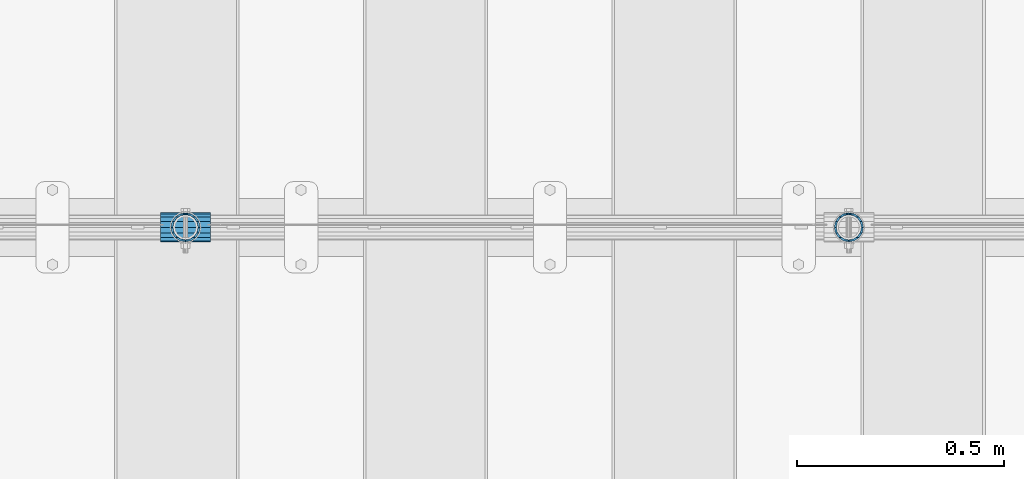
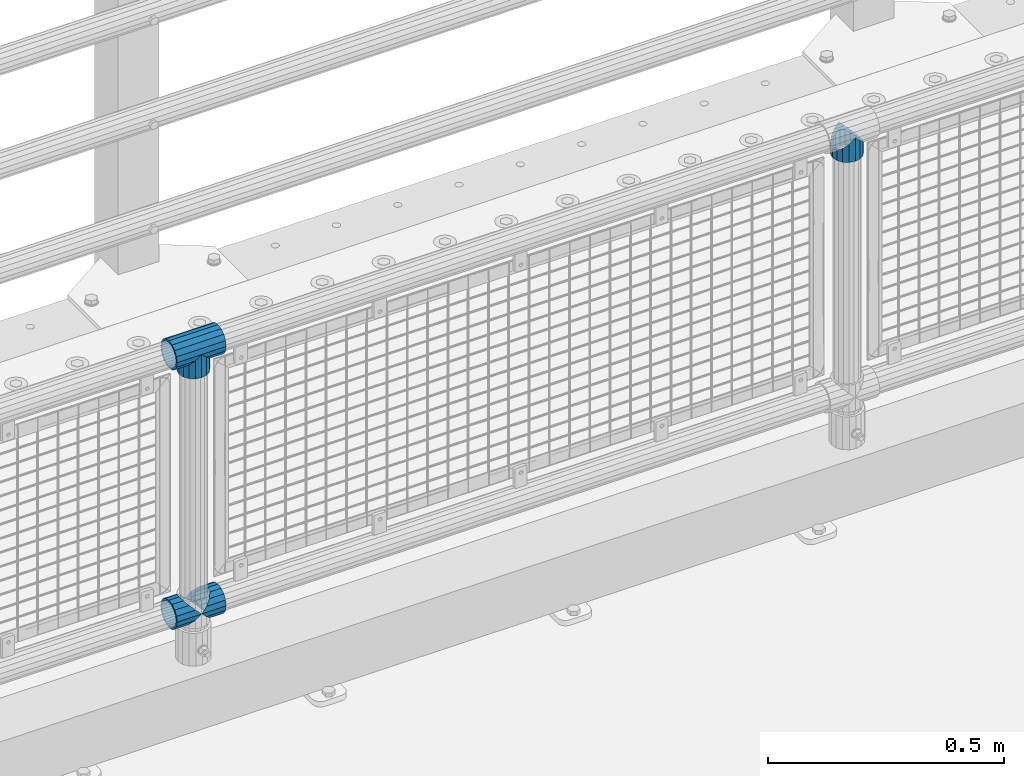
# One storey, part 154 of 257: 5 beams.
"""IFC2X3 building model written with IfcOpenShell, lengths in millimetres."""

from ifc_helpers import new_model, si_unit, frame, origin_with_axes, place, context, subcontext, project, spatial, faceted_brep, material, type_object, element, save


model = new_model("IFC2X3")

# Units and contexts
model_context = context("Model", 3, precision=1e-05, world=origin_with_axes())
body_context = subcontext(model_context, "Body", "Model", "MODEL_VIEW")
ifc_project = project(units=[si_unit("LENGTHUNIT", "METRE", prefix="MILLI"), si_unit("AREAUNIT", "SQUARE_METRE"), si_unit("VOLUMEUNIT", "CUBIC_METRE"), si_unit("MASSUNIT", "GRAM", prefix="KILO"), si_unit("TIMEUNIT", "SECOND"), si_unit("PLANEANGLEUNIT", "RADIAN"), si_unit("SOLIDANGLEUNIT", "STERADIAN"), si_unit("THERMODYNAMICTEMPERATUREUNIT", "DEGREE_CELSIUS"), si_unit("LUMINOUSINTENSITYUNIT", "LUMEN")], contexts=[model_context])

# Site, building, storey
site_placement = place(None, origin_with_axes())
site = spatial("IfcSite", under=ifc_project, at=site_placement, CompositionType="ELEMENT")
building_placement = place(site_placement, origin_with_axes())
building = spatial("IfcBuilding", under=site, at=building_placement, Name="Standard", CompositionType="ELEMENT")
storey_placement = place(building_placement, origin_with_axes())
storey = spatial("IfcBuildingStorey", under=building, at=storey_placement, Name="Undefined", CompositionType="ELEMENT", Elevation=0.0)

# Beams
ifc_material = material(Name="Misc_Undefined")
beam_type = type_object("IfcBeamType", PredefinedType="NOTDEFINED")
beam_1_placement = place(storey_placement, frame((51071.0, 10664.5, 969.849999999999), z_axis=(0.0, 1.0, 0.0), x_axis=(0.0, 0.0, -1.0)))
element("IfcBeam", 1, at=beam_1_placement, inside=storey, type_object=beam_type, material=ifc_material, context=body_context, shape_type="Brep", body=[
    faceted_brep([(0.0, 0.0, 35.1499999999996), (13.4513226476338, 13.4513226476329, 32.4743655677721), (13.4513226476338, -13.4513226476329, 32.4743655677721), (32.4743655677739, -32.4743655677717, -13.4513226476338), (32.4743655677739, -26.8123795176755, -13.4513226476338), (27.1226768591005, -21.4606908090117, -21.4606908090118), (24.8548033587067, -16.3810424080045, -24.8548033587067), (24.8548033587067, -24.8548033587072, -24.8548033587067), (13.4513226476338, -13.4513226476329, -32.4743655677721), (13.4513226476338, 13.4513226476329, -32.4743655677721), (0.0, 0.0, -35.1499999999996), (20.0882031229849, -11.6144421722805, -28.0397438117179), (16.6306603983685, 0.0, -30.3500000000004), (20.0882031229849, 11.6144421722805, -28.0397438117179), (24.8548033587067, 16.3810424080013, -24.8548033587067), (24.8548033587067, 24.8548033587072, -24.8548033587067), (32.4743655677739, 26.8123795176754, -13.4513226476338), (32.4743655677739, 32.4743655677717, -13.4513226476338), (27.1226768591005, 21.4606908090117, -21.4606908090118), (35.1500000000015, 30.35, 0.0), (35.1500000000015, 35.15, 0.0), (32.8397438117172, 28.0397438117175, -11.6144421722802), (32.8397438117172, 28.0397438117175, 11.6144421722802), (32.4743655677739, 26.8123795176755, 13.4513226476338), (32.4743655677739, 32.4743655677717, 13.4513226476338), (27.122676859115, 21.4606908090117, 21.4606908090118), (24.8548033587067, 16.3810424080013, 24.8548033587067), (24.8548033587067, 24.8548033587072, 24.8548033587067), (20.0882031229849, 11.6144421722805, 28.0397438117179), (16.6306603983758, 0.0, 30.3500000000004), (20.0882031229849, -11.6144421722805, 28.0397438117179), (24.8548033587067, -16.3810424080013, 24.8548033587067), (24.8548033587067, -24.8548033587072, 24.8548033587067), (27.122676859115, -21.4606908090117, 21.4606908090118), (32.4743655677739, -26.8123795176754, 13.4513226476338), (32.4743655677739, -32.4743655677717, 13.4513226476338), (32.8397438117172, -28.0397438117175, 11.6144421722802), (35.1500000000015, -30.35, 0.0), (35.1500000000015, -35.1499999999996, 0.0), (32.8397438117172, -28.0397438117175, -11.6144421722802), (60.1500000000015, -24.8548033587072, -24.8548033587067), (60.1500000000015, -32.4743655677717, -13.4513226476338), (60.1500000000015, -13.4513226476329, -32.4743655677721), (60.1500000000015, 0.0, -35.1499999999996), (60.1500000000015, 13.4513226476329, -32.4743655677721), (60.1500000000015, 24.8548033587072, -24.8548033587067), (60.1500000000015, 32.4743655677717, -13.4513226476338), (60.1500000000015, 35.15, 0.0), (60.1500000000015, 32.4743655677717, 13.4513226476338), (60.1500000000015, 24.8548033587072, 24.8548033587067), (60.1500000000015, 13.4513226476329, 32.4743655677721), (60.1500000000015, 0.0, 35.1499999999996), (60.1500000000015, -13.4513226476329, 32.4743655677721), (60.1500000000015, -24.8548033587072, 24.8548033587067), (60.1500000000015, -32.4743655677717, 13.4513226476338), (60.1500000000015, -35.15, 0.0), (60.1500000000015, -21.4606908090117, 21.4606908090118), (60.1500000000015, -11.6144421722805, 28.0397438117179), (60.1500000000015, 0.0, 30.3500000000004), (60.1500000000015, 11.6144421722805, 28.0397438117179), (60.1500000000015, 21.4606908090117, 21.4606908090118), (60.1500000000015, 28.0397438117175, 11.6144421722802), (60.1500000000015, 30.35, 0.0), (60.1500000000015, 28.0397438117175, -11.6144421722802), (60.1500000000015, 21.4606908090117, -21.4606908090118), (60.1500000000015, 11.6144421722805, -28.0397438117179), (60.1500000000015, 0.0, -30.3500000000004), (60.1500000000015, -11.6144421722805, -28.0397438117179), (60.1500000000015, -21.4606908090117, -21.4606908090118), (60.1500000000015, -28.0397438117175, -11.6144421722802), (60.1500000000015, -30.35, 0.0), (60.1500000000015, -28.0397438117175, 11.6144421722802)], [[[0, 1, 2]], [[3, 4, 5, 6, 7]], [[8, 9, 10]], [[7, 6, 11, 12, 13, 14, 15, 9, 8]], [[16, 17, 15, 14, 18]], [[19, 20, 17, 16, 21]], [[22, 23, 24, 20, 19]], [[25, 26, 27, 24, 23]], [[2, 1, 27, 26, 28, 29, 30, 31, 32]], [[32, 31, 33, 34, 35]], [[35, 34, 36, 37, 38]], [[38, 37, 39, 4, 3]], [[40, 41, 3, 7]], [[42, 40, 7, 8]], [[43, 42, 8, 10]], [[44, 43, 10, 9]], [[45, 44, 9, 15]], [[46, 45, 15, 17]], [[47, 46, 17, 20]], [[48, 47, 20, 24]], [[49, 48, 24, 27]], [[50, 49, 27, 1]], [[51, 50, 1, 0]], [[52, 51, 0, 2]], [[53, 52, 2, 32]], [[54, 53, 32, 35]], [[55, 54, 35, 38]], [[41, 55, 38, 3]], [[40, 42, 43, 44, 45, 46, 47, 48, 49, 50, 51, 52, 53, 54, 55, 41], [56, 57, 58, 59, 60, 61, 62, 63, 64, 65, 66, 67, 68, 69, 70, 71]], [[71, 70, 37, 36]], [[33, 56, 71, 36, 34]], [[30, 57, 56, 33, 31]], [[58, 57, 30, 29]], [[59, 58, 29, 28]], [[60, 59, 28, 26, 25]], [[61, 60, 25, 23, 22]], [[62, 61, 22, 19]], [[63, 62, 19, 21]], [[18, 64, 63, 21, 16]], [[13, 65, 64, 18, 14]], [[66, 65, 13, 12]], [[67, 66, 12, 11]], [[68, 67, 11, 6, 5]], [[69, 68, 5, 4, 39]], [[70, 69, 39, 37]]]),
])
beam_2_placement = place(storey_placement, frame((49471.0, 10664.5, 969.849999999999), z_axis=(0.0, 1.0, 0.0), x_axis=(0.0, 0.0, -1.0)))
element("IfcBeam", 2, at=beam_2_placement, inside=storey, type_object=beam_type, material=ifc_material, context=body_context, shape_type="Brep", body=[
    faceted_brep([(0.0, 0.0, 35.1499999999996), (13.4513226476338, 13.4513226476329, 32.4743655677721), (13.4513226476338, -13.4513226476329, 32.4743655677721), (32.4743655677739, -32.4743655677717, -13.4513226476338), (32.4743655677739, -26.8123795176755, -13.4513226476338), (27.1226768591005, -21.4606908090117, -21.4606908090118), (24.8548033587067, -16.3810424080045, -24.8548033587067), (24.8548033587067, -24.8548033587072, -24.8548033587067), (13.4513226476338, -13.4513226476329, -32.4743655677721), (13.4513226476338, 13.4513226476329, -32.4743655677721), (0.0, 0.0, -35.1499999999996), (20.0882031229849, -11.6144421722805, -28.0397438117179), (16.6306603983685, 0.0, -30.3500000000004), (20.0882031229849, 11.6144421722805, -28.0397438117179), (24.8548033587067, 16.3810424080013, -24.8548033587067), (24.8548033587067, 24.8548033587072, -24.8548033587067), (32.4743655677739, 26.8123795176754, -13.4513226476338), (32.4743655677739, 32.4743655677717, -13.4513226476338), (27.1226768591005, 21.4606908090117, -21.4606908090118), (35.1500000000015, 30.35, 0.0), (35.1500000000015, 35.15, 0.0), (32.8397438117172, 28.0397438117175, -11.6144421722802), (32.8397438117172, 28.0397438117175, 11.6144421722802), (32.4743655677739, 26.8123795176755, 13.4513226476338), (32.4743655677739, 32.4743655677717, 13.4513226476338), (27.122676859115, 21.4606908090117, 21.4606908090118), (24.8548033587067, 16.3810424080013, 24.8548033587067), (24.8548033587067, 24.8548033587072, 24.8548033587067), (20.0882031229849, 11.6144421722805, 28.0397438117179), (16.6306603983758, 0.0, 30.3500000000004), (20.0882031229849, -11.6144421722805, 28.0397438117179), (24.8548033587067, -16.3810424080013, 24.8548033587067), (24.8548033587067, -24.8548033587072, 24.8548033587067), (27.122676859115, -21.4606908090117, 21.4606908090118), (32.4743655677739, -26.8123795176754, 13.4513226476338), (32.4743655677739, -32.4743655677717, 13.4513226476338), (32.8397438117172, -28.0397438117175, 11.6144421722802), (35.1500000000015, -30.35, 0.0), (35.1500000000015, -35.1499999999996, 0.0), (32.8397438117172, -28.0397438117175, -11.6144421722802), (60.1500000000015, -24.8548033587072, -24.8548033587067), (60.1500000000015, -32.4743655677717, -13.4513226476338), (60.1500000000015, -13.4513226476329, -32.4743655677721), (60.1500000000015, 0.0, -35.1499999999996), (60.1500000000015, 13.4513226476329, -32.4743655677721), (60.1500000000015, 24.8548033587072, -24.8548033587067), (60.1500000000015, 32.4743655677717, -13.4513226476338), (60.1500000000015, 35.15, 0.0), (60.1500000000015, 32.4743655677717, 13.4513226476338), (60.1500000000015, 24.8548033587072, 24.8548033587067), (60.1500000000015, 13.4513226476329, 32.4743655677721), (60.1500000000015, 0.0, 35.1499999999996), (60.1500000000015, -13.4513226476329, 32.4743655677721), (60.1500000000015, -24.8548033587072, 24.8548033587067), (60.1500000000015, -32.4743655677717, 13.4513226476338), (60.1500000000015, -35.15, 0.0), (60.1500000000015, -21.4606908090117, 21.4606908090118), (60.1500000000015, -11.6144421722805, 28.0397438117179), (60.1500000000015, 0.0, 30.3500000000004), (60.1500000000015, 11.6144421722805, 28.0397438117179), (60.1500000000015, 21.4606908090117, 21.4606908090118), (60.1500000000015, 28.0397438117175, 11.6144421722802), (60.1500000000015, 30.35, 0.0), (60.1500000000015, 28.0397438117175, -11.6144421722802), (60.1500000000015, 21.4606908090117, -21.4606908090118), (60.1500000000015, 11.6144421722805, -28.0397438117179), (60.1500000000015, 0.0, -30.3500000000004), (60.1500000000015, -11.6144421722805, -28.0397438117179), (60.1500000000015, -21.4606908090117, -21.4606908090118), (60.1500000000015, -28.0397438117175, -11.6144421722802), (60.1500000000015, -30.35, 0.0), (60.1500000000015, -28.0397438117175, 11.6144421722802)], [[[0, 1, 2]], [[3, 4, 5, 6, 7]], [[8, 9, 10]], [[7, 6, 11, 12, 13, 14, 15, 9, 8]], [[16, 17, 15, 14, 18]], [[19, 20, 17, 16, 21]], [[22, 23, 24, 20, 19]], [[25, 26, 27, 24, 23]], [[2, 1, 27, 26, 28, 29, 30, 31, 32]], [[32, 31, 33, 34, 35]], [[35, 34, 36, 37, 38]], [[38, 37, 39, 4, 3]], [[40, 41, 3, 7]], [[42, 40, 7, 8]], [[43, 42, 8, 10]], [[44, 43, 10, 9]], [[45, 44, 9, 15]], [[46, 45, 15, 17]], [[47, 46, 17, 20]], [[48, 47, 20, 24]], [[49, 48, 24, 27]], [[50, 49, 27, 1]], [[51, 50, 1, 0]], [[52, 51, 0, 2]], [[53, 52, 2, 32]], [[54, 53, 32, 35]], [[55, 54, 35, 38]], [[41, 55, 38, 3]], [[40, 42, 43, 44, 45, 46, 47, 48, 49, 50, 51, 52, 53, 54, 55, 41], [56, 57, 58, 59, 60, 61, 62, 63, 64, 65, 66, 67, 68, 69, 70, 71]], [[71, 70, 37, 36]], [[33, 56, 71, 36, 34]], [[30, 57, 56, 33, 31]], [[58, 57, 30, 29]], [[59, 58, 29, 28]], [[60, 59, 28, 26, 25]], [[61, 60, 25, 23, 22]], [[62, 61, 22, 19]], [[63, 62, 19, 21]], [[18, 64, 63, 21, 16]], [[13, 65, 64, 18, 14]], [[66, 65, 13, 12]], [[67, 66, 12, 11]], [[68, 67, 11, 6, 5]], [[69, 68, 5, 4, 39]], [[70, 69, 39, 37]]]),
])
beam_3_placement = place(storey_placement, frame((49410.85, 10664.5, 969.849999999999), z_axis=(0.0, 0.0, 1.0), x_axis=(1.0, 0.0, 0.0)))
element("IfcBeam", 3, at=beam_3_placement, inside=storey, type_object=beam_type, material=ifc_material, context=body_context, shape_type="Brep", body=[
    faceted_brep([(88.1897438117157, -11.6144421722802, -28.0397438117176), (88.1897438117157, -11.6144421722802, -32.8397438117175), (86.962379517674, -13.4513226476338, -32.4743655677718), (81.6106908090151, -21.4606908090118, -27.122676859108), (81.6106908090151, -21.4606908090118, -21.4606908090117), (76.5310424080017, -24.8548033587067, -24.8548033587072), (71.7644421722798, -28.0397438117179, -20.0882031229829), (71.7644421722798, -28.0397438117179, -11.6144421722805), (60.1500000000015, -30.3500000000004, -16.6306603983671), (60.1500000000015, -30.35, 0.0), (48.5355578277231, -28.0397438117179, -20.0882031229829), (48.5355578277231, -28.0397438117179, -11.6144421722805), (43.7689575920012, -24.8548033587067, -24.8548033587072), (38.6893091909878, -21.4606908090118, -27.122676859108), (38.6893091909878, -21.4606908090118, -21.4606908090117), (33.3376204823144, -13.4513226476338, -32.4743655677718), (32.1102561882872, -11.6144421722802, -32.8397438117175), (32.1102561882872, -11.6144421722802, -28.0397438117176), (29.8000000000029, 0.0, -35.15), (29.8000000000029, 0.0, -30.35), (32.1102561882872, 11.6144421722802, -32.8397438117178), (32.1102561882872, 11.6144421722802, -28.0397438117176), (33.3376204823289, 13.4513226476338, -32.4743655677718), (38.6893091909878, 21.4606908090118, -27.1226768591091), (38.6893091909878, 21.4606908090118, -21.4606908090117), (43.7689575920012, 24.8548033587067, -24.8548033587072), (48.5355578277231, 28.0397438117179, -20.0882031229829), (48.5355578277231, 28.0397438117179, -11.6144421722805), (60.1500000000015, 30.3500000000004, -16.6306603983671), (60.1500000000015, 30.35, 0.0), (71.7644421722798, 28.0397438117179, -20.0882031229829), (71.7644421722798, 28.0397438117179, -11.6144421722805), (76.5310424080017, 24.8548033587067, -24.8548033587072), (81.6106908090151, 21.4606908090118, -27.1226768591091), (81.6106908090151, 21.4606908090118, -21.4606908090117), (86.9623795176813, 13.4513226476338, -32.4743655677718), (88.1897438117157, 11.6144421722802, -32.8397438117178), (88.1897438117157, 11.6144421722802, -28.0397438117176), (90.5, 0.0, -35.15), (90.5, 0.0, -30.35), (0.0, -21.4606908090118, -21.4606908090136), (0.0, -28.0397438117179, -11.6144421722784), (0.0, -11.6144421722802, -28.0397438117143), (0.0, 0.0, -30.3499999999985), (0.0, 11.6144421722802, -28.0397438117143), (0.0, 21.4606908090118, -21.4606908090136), (0.0, 28.0397438117179, -11.6144421722784), (0.0, 30.3500000000004, 0.0), (0.0, 32.4743655677721, -13.4513226476338), (0.0, 35.1499999999996, 0.0), (120.300000000003, 35.1499999999996, 0.0), (120.300000000003, 32.4743655677721, -13.4513226476329), (0.0, 32.4743655677721, 13.4513226476338), (120.300000000003, 32.4743655677721, 13.4513226476329), (0.0, 24.8548033587067, 24.8548033587067), (120.300000000003, 24.8548033587067, 24.8548033587072), (0.0, 13.4513226476338, 32.4743655677739), (120.300000000003, 13.4513226476338, 32.4743655677718), (0.0, 0.0, 35.1499999999996), (120.300000000003, 0.0, 35.15), (0.0, -13.4513226476338, 32.4743655677739), (120.300000000003, -13.4513226476338, 32.4743655677718), (0.0, -24.8548033587067, 24.8548033587067), (120.300000000003, -24.8548033587067, 24.8548033587072), (0.0, -32.4743655677721, 13.4513226476338), (120.300000000003, -32.4743655677721, 13.4513226476329), (0.0, -35.1499999999996, 0.0), (120.300000000003, -35.1499999999996, 0.0), (0.0, -32.4743655677721, -13.4513226476338), (120.300000000003, -32.4743655677721, -13.4513226476329), (0.0, 24.8548033587067, -24.8548033587067), (0.0, 13.4513226476338, -32.4743655677739), (0.0, 0.0, -35.1499999999996), (0.0, -13.4513226476338, -32.4743655677739), (0.0, -24.8548033587067, -24.8548033587067), (0.0, 28.0397438117179, 11.6144421722784), (0.0, 21.4606908090118, 21.4606908090136), (0.0, 11.6144421722802, 28.0397438117143), (0.0, 0.0, 30.3499999999985), (0.0, -11.6144421722802, 28.0397438117143), (0.0, -21.4606908090118, 21.4606908090136), (0.0, -28.0397438117179, 11.6144421722784), (0.0, -30.3500000000004, 0.0), (120.300000000003, -30.3500000000004, 0.0), (120.300000000003, -28.0397438117179, -11.6144421722805), (120.300000000003, -21.4606908090118, -21.4606908090117), (120.300000000003, -11.6144421722802, -28.0397438117176), (120.300000000003, 0.0, -30.35), (120.300000000003, 21.4606908090118, -21.4606908090117), (120.300000000003, 28.0397438117179, -11.6144421722805), (120.300000000003, 11.6144421722802, -28.0397438117176), (120.300000000003, 30.3500000000004, 0.0), (120.300000000003, 28.0397438117179, 11.6144421722805), (120.300000000003, 21.4606908090118, 21.4606908090117), (120.300000000003, 11.6144421722802, 28.0397438117176), (120.300000000003, 0.0, 30.35), (120.300000000003, -11.6144421722802, 28.0397438117176), (120.300000000003, -21.4606908090118, 21.4606908090117), (120.300000000003, -28.0397438117179, 11.6144421722805), (120.300000000003, -24.8548033587067, -24.8548033587072), (120.300000000003, -13.4513226476338, -32.4743655677718), (120.300000000003, 0.0, -35.15), (120.300000000003, 13.4513226476338, -32.4743655677718), (120.300000000003, 24.8548033587067, -24.8548033587072)], [[[0, 1, 2, 3, 4]], [[4, 3, 5, 6, 7]], [[7, 6, 8, 9]], [[9, 8, 10, 11]], [[11, 10, 12, 13, 14]], [[14, 13, 15, 16, 17]], [[17, 16, 18, 19]], [[19, 18, 20, 21]], [[21, 20, 22, 23, 24]], [[24, 23, 25, 26, 27]], [[27, 26, 28, 29]], [[29, 28, 30, 31]], [[31, 30, 32, 33, 34]], [[34, 33, 35, 36, 37]], [[37, 36, 38, 39]], [[39, 38, 1, 0]], [[40, 41, 11, 14]], [[42, 40, 14, 17]], [[43, 42, 17, 19]], [[44, 43, 19, 21]], [[45, 44, 21, 24]], [[46, 45, 24, 27]], [[47, 46, 27, 29]], [[48, 49, 50, 51]], [[49, 52, 53, 50]], [[52, 54, 55, 53]], [[54, 56, 57, 55]], [[56, 58, 59, 57]], [[58, 60, 61, 59]], [[60, 62, 63, 61]], [[62, 64, 65, 63]], [[64, 66, 67, 65]], [[66, 68, 69, 67]], [[64, 62, 60, 58, 56, 54, 52, 49, 48, 70, 71, 72, 73, 74, 68, 66], [41, 40, 42, 43, 44, 45, 46, 47, 75, 76, 77, 78, 79, 80, 81, 82]], [[41, 82, 9, 11]], [[83, 84, 7, 9]], [[84, 85, 4, 7]], [[85, 86, 0, 4]], [[86, 87, 39, 0]], [[88, 89, 31, 34]], [[90, 88, 34, 37]], [[87, 90, 37, 39]], [[89, 91, 29, 31]], [[75, 47, 29, 91, 92]], [[76, 75, 92, 93]], [[77, 76, 93, 94]], [[78, 77, 94, 95]], [[79, 78, 95, 96]], [[80, 79, 96, 97]], [[81, 80, 97, 98]], [[9, 82, 81, 98, 83]], [[99, 100, 101, 102, 103, 51, 50, 53, 55, 57, 59, 61, 63, 65, 67, 69], [97, 96, 95, 94, 93, 92, 91, 89, 88, 90, 87, 86, 85, 84, 83, 98]], [[35, 102, 101, 38, 36]], [[32, 103, 102, 35, 33]], [[28, 26, 25, 70, 48, 51, 103, 32, 30]], [[22, 71, 70, 25, 23]], [[18, 72, 71, 22, 20]], [[73, 72, 18, 16, 15]], [[74, 73, 15, 13, 12]], [[99, 69, 68, 74, 12, 10, 8, 6, 5]], [[100, 99, 5, 3, 2]], [[101, 100, 2, 1, 38]]]),
])
beam_4_placement = place(storey_placement, frame((49410.85, 10664.5, 298.17), z_axis=(0.0, 1.0, 0.0), x_axis=(1.0, 0.0, 0.0)))
element("IfcBeam", 4, at=beam_4_placement, inside=storey, type_object=beam_type, material=ifc_material, context=body_context, shape_type="Brep", body=[
    faceted_brep([(60.1500000000015, 0.0, -35.1499999999996), (46.6986773523677, 13.4513226476329, -32.4743655677721), (46.6986773523677, -13.4513226476329, -32.4743655677721), (33.0273231408937, 21.4606908090117, 21.4606908090118), (27.6756344322275, 26.8123795176764, 13.4513226476338), (27.6756344322275, 32.4743655677717, 13.4513226476338), (35.2951966412948, 24.8548033587072, 24.8548033587067), (35.2951966412948, 16.3810424080013, 24.8548033587067), (27.3102561882843, 28.0397438117175, 11.6144421722802), (25.0, 30.35, 0.0), (25.0, 35.15, 0.0), (27.6756344322275, 26.8123795176754, -13.4513226476338), (27.6756344322275, 32.4743655677717, -13.4513226476338), (27.3102561882843, 28.0397438117175, -11.6144421722802), (35.2951966412948, 16.3810424080013, -24.8548033587067), (35.2951966412948, 24.8548033587072, -24.8548033587067), (33.0273231408864, 21.4606908090117, -21.4606908090118), (40.0617968770239, 11.6144421722805, -28.0397438117179), (43.5193396016475, 0.0, -30.3500000000004), (40.0617968770239, -11.6144421722805, -28.0397438117179), (35.2951966412948, -16.3810424080078, -24.8548033587067), (35.2951966412948, -24.8548033587072, -24.8548033587067), (33.0273231408864, -21.4606908090117, -21.4606908090118), (27.6756344322275, -26.8123795176764, -13.4513226476338), (27.6756344322275, -32.4743655677717, -13.4513226476338), (27.3102561882843, -28.0397438117175, -11.6144421722802), (25.0, -30.35, 0.0), (25.0, -35.15, 0.0), (27.3102561882843, -28.0397438117175, 11.6144421722802), (27.6756344322275, -26.8123795176754, 13.4513226476338), (27.6756344322275, -32.4743655677717, 13.4513226476338), (33.0273231408937, -21.4606908090117, 21.4606908090118), (35.2951966412948, -16.3810424080045, 24.8548033587067), (35.2951966412948, -24.8548033587072, 24.8548033587067), (60.1500000000015, 0.0, 35.1499999999996), (46.6986773523677, -13.4513226476329, 32.4743655677721), (46.6986773523677, 13.4513226476329, 32.4743655677721), (40.0617968770166, -11.6144421722805, 28.0397438117179), (43.519339601633, 0.0, 30.3500000000004), (40.0617968770166, 11.6144421722805, 28.0397438117179), (0.0, -32.4743655677721, -13.4513226476338), (0.0, -24.8548033587067, -24.8548033587067), (0.0, -13.4513226476338, -32.4743655677739), (0.0, 0.0, -35.1499999999996), (0.0, 13.4513226476338, -32.4743655677739), (0.0, 24.8548033587067, -24.8548033587067), (0.0, 32.4743655677721, -13.4513226476338), (0.0, 35.1499999999996, 0.0), (0.0, 32.4743655677721, 13.4513226476338), (0.0, 24.8548033587067, 24.8548033587067), (0.0, 13.4513226476338, 32.4743655677739), (0.0, 0.0, 35.1499999999996), (0.0, -32.4743655677721, 13.4513226476338), (0.0, -35.1499999999996, 0.0), (0.0, -24.8548033587067, 24.8548033587067), (0.0, -13.4513226476338, 32.4743655677739), (0.0, -28.0397438117179, -11.6144421722784), (0.0, -21.4606908090118, -21.4606908090136), (0.0, -11.6144421722802, -28.0397438117143), (0.0, 0.0, -30.3499999999985), (0.0, 11.6144421722802, -28.0397438117143), (0.0, 21.4606908090118, -21.4606908090136), (0.0, 28.0397438117179, -11.6144421722784), (0.0, 30.3500000000004, 0.0), (0.0, 28.0397438117179, 11.6144421722784), (0.0, 21.4606908090118, 21.4606908090136), (0.0, 11.6144421722802, 28.0397438117143), (0.0, 0.0, 30.3499999999985), (0.0, -11.6144421722802, 28.0397438117143), (0.0, -21.4606908090118, 21.4606908090136), (0.0, -28.0397438117179, 11.6144421722784), (0.0, -30.3500000000004, 0.0)], [[[0, 1, 2]], [[3, 4, 5, 6, 7]], [[8, 9, 10, 5, 4]], [[11, 12, 10, 9, 13]], [[14, 15, 12, 11, 16]], [[2, 1, 15, 14, 17, 18, 19, 20, 21]], [[21, 20, 22, 23, 24]], [[24, 23, 25, 26, 27]], [[27, 26, 28, 29, 30]], [[30, 29, 31, 32, 33]], [[34, 35, 36]], [[33, 32, 37, 38, 39, 7, 6, 36, 35]], [[40, 41, 21, 24]], [[41, 42, 2, 21]], [[42, 43, 0, 2]], [[43, 44, 1, 0]], [[44, 45, 15, 1]], [[45, 46, 12, 15]], [[46, 47, 10, 12]], [[47, 48, 5, 10]], [[48, 49, 6, 5]], [[49, 50, 36, 6]], [[50, 51, 34, 36]], [[52, 53, 27, 30]], [[54, 52, 30, 33]], [[55, 54, 33, 35]], [[51, 55, 35, 34]], [[53, 40, 24, 27]], [[52, 54, 55, 51, 50, 49, 48, 47, 46, 45, 44, 43, 42, 41, 40, 53], [56, 57, 58, 59, 60, 61, 62, 63, 64, 65, 66, 67, 68, 69, 70, 71]], [[68, 67, 38, 37]], [[31, 69, 68, 37, 32]], [[28, 70, 69, 31, 29]], [[71, 70, 28, 26]], [[56, 71, 26, 25]], [[57, 56, 25, 23, 22]], [[58, 57, 22, 20, 19]], [[59, 58, 19, 18]], [[60, 59, 18, 17]], [[16, 61, 60, 17, 14]], [[13, 62, 61, 16, 11]], [[63, 62, 13, 9]], [[64, 63, 9, 8]], [[65, 64, 8, 4, 3]], [[66, 65, 3, 7, 39]], [[67, 66, 39, 38]]]),
])
beam_5_placement = place(storey_placement, frame((49471.0, 10664.5, 298.17), z_axis=(0.0, 1.0, 0.0), x_axis=(1.0, 0.0, 0.0)))
element("IfcBeam", 5, at=beam_5_placement, inside=storey, type_object=beam_type, material=ifc_material, context=body_context, shape_type="Brep", body=[
    faceted_brep([(0.0, 0.0, 35.1499999999996), (13.4513226476338, 13.4513226476329, 32.4743655677721), (13.4513226476338, -13.4513226476329, 32.4743655677721), (32.4743655677739, -32.4743655677717, -13.4513226476338), (32.4743655677739, -26.8123795176755, -13.4513226476338), (27.1226768591005, -21.4606908090117, -21.4606908090118), (24.8548033587067, -16.3810424080045, -24.8548033587067), (24.8548033587067, -24.8548033587072, -24.8548033587067), (13.4513226476338, -13.4513226476329, -32.4743655677721), (13.4513226476338, 13.4513226476329, -32.4743655677721), (0.0, 0.0, -35.1499999999996), (20.0882031229849, -11.6144421722805, -28.0397438117179), (16.6306603983685, 0.0, -30.3500000000004), (20.0882031229849, 11.6144421722805, -28.0397438117179), (24.8548033587067, 16.3810424080013, -24.8548033587067), (24.8548033587067, 24.8548033587072, -24.8548033587067), (32.4743655677739, 26.8123795176754, -13.4513226476338), (32.4743655677739, 32.4743655677717, -13.4513226476338), (27.1226768591005, 21.4606908090117, -21.4606908090118), (35.1500000000015, 30.35, 0.0), (35.1500000000015, 35.15, 0.0), (32.8397438117172, 28.0397438117175, -11.6144421722802), (32.8397438117172, 28.0397438117175, 11.6144421722802), (32.4743655677739, 26.8123795176755, 13.4513226476338), (32.4743655677739, 32.4743655677717, 13.4513226476338), (27.122676859115, 21.4606908090117, 21.4606908090118), (24.8548033587067, 16.3810424080013, 24.8548033587067), (24.8548033587067, 24.8548033587072, 24.8548033587067), (20.0882031229849, 11.6144421722805, 28.0397438117179), (16.6306603983758, 0.0, 30.3500000000004), (20.0882031229849, -11.6144421722805, 28.0397438117179), (24.8548033587067, -16.3810424080013, 24.8548033587067), (24.8548033587067, -24.8548033587072, 24.8548033587067), (27.122676859115, -21.4606908090117, 21.4606908090118), (32.4743655677739, -26.8123795176754, 13.4513226476338), (32.4743655677739, -32.4743655677717, 13.4513226476338), (32.8397438117172, -28.0397438117175, 11.6144421722802), (35.1500000000015, -30.35, 0.0), (35.1500000000015, -35.1499999999996, 0.0), (32.8397438117172, -28.0397438117175, -11.6144421722802), (60.1500000000015, -24.8548033587072, -24.8548033587067), (60.1500000000015, -32.4743655677717, -13.4513226476338), (60.1500000000015, -13.4513226476329, -32.4743655677721), (60.1500000000015, 0.0, -35.1499999999996), (60.1500000000015, 13.4513226476329, -32.4743655677721), (60.1500000000015, 24.8548033587072, -24.8548033587067), (60.1500000000015, 32.4743655677717, -13.4513226476338), (60.1500000000015, 35.15, 0.0), (60.1500000000015, 32.4743655677717, 13.4513226476338), (60.1500000000015, 24.8548033587072, 24.8548033587067), (60.1500000000015, 13.4513226476329, 32.4743655677721), (60.1500000000015, 0.0, 35.1499999999996), (60.1500000000015, -13.4513226476329, 32.4743655677721), (60.1500000000015, -24.8548033587072, 24.8548033587067), (60.1500000000015, -32.4743655677717, 13.4513226476338), (60.1500000000015, -35.15, 0.0), (60.1500000000015, -21.4606908090117, 21.4606908090118), (60.1500000000015, -11.6144421722805, 28.0397438117179), (60.1500000000015, 0.0, 30.3500000000004), (60.1500000000015, 11.6144421722805, 28.0397438117179), (60.1500000000015, 21.4606908090117, 21.4606908090118), (60.1500000000015, 28.0397438117175, 11.6144421722802), (60.1500000000015, 30.35, 0.0), (60.1500000000015, 28.0397438117175, -11.6144421722802), (60.1500000000015, 21.4606908090117, -21.4606908090118), (60.1500000000015, 11.6144421722805, -28.0397438117179), (60.1500000000015, 0.0, -30.3500000000004), (60.1500000000015, -11.6144421722805, -28.0397438117179), (60.1500000000015, -21.4606908090117, -21.4606908090118), (60.1500000000015, -28.0397438117175, -11.6144421722802), (60.1500000000015, -30.35, 0.0), (60.1500000000015, -28.0397438117175, 11.6144421722802)], [[[0, 1, 2]], [[3, 4, 5, 6, 7]], [[8, 9, 10]], [[7, 6, 11, 12, 13, 14, 15, 9, 8]], [[16, 17, 15, 14, 18]], [[19, 20, 17, 16, 21]], [[22, 23, 24, 20, 19]], [[25, 26, 27, 24, 23]], [[2, 1, 27, 26, 28, 29, 30, 31, 32]], [[32, 31, 33, 34, 35]], [[35, 34, 36, 37, 38]], [[38, 37, 39, 4, 3]], [[40, 41, 3, 7]], [[42, 40, 7, 8]], [[43, 42, 8, 10]], [[44, 43, 10, 9]], [[45, 44, 9, 15]], [[46, 45, 15, 17]], [[47, 46, 17, 20]], [[48, 47, 20, 24]], [[49, 48, 24, 27]], [[50, 49, 27, 1]], [[51, 50, 1, 0]], [[52, 51, 0, 2]], [[53, 52, 2, 32]], [[54, 53, 32, 35]], [[55, 54, 35, 38]], [[41, 55, 38, 3]], [[40, 42, 43, 44, 45, 46, 47, 48, 49, 50, 51, 52, 53, 54, 55, 41], [56, 57, 58, 59, 60, 61, 62, 63, 64, 65, 66, 67, 68, 69, 70, 71]], [[71, 70, 37, 36]], [[33, 56, 71, 36, 34]], [[30, 57, 56, 33, 31]], [[58, 57, 30, 29]], [[59, 58, 29, 28]], [[60, 59, 28, 26, 25]], [[61, 60, 25, 23, 22]], [[62, 61, 22, 19]], [[63, 62, 19, 21]], [[18, 64, 63, 21, 16]], [[13, 65, 64, 18, 14]], [[66, 65, 13, 12]], [[67, 66, 12, 11]], [[68, 67, 11, 6, 5]], [[69, 68, 5, 4, 39]], [[70, 69, 39, 37]]]),
])

save(model, "model.ifc")
